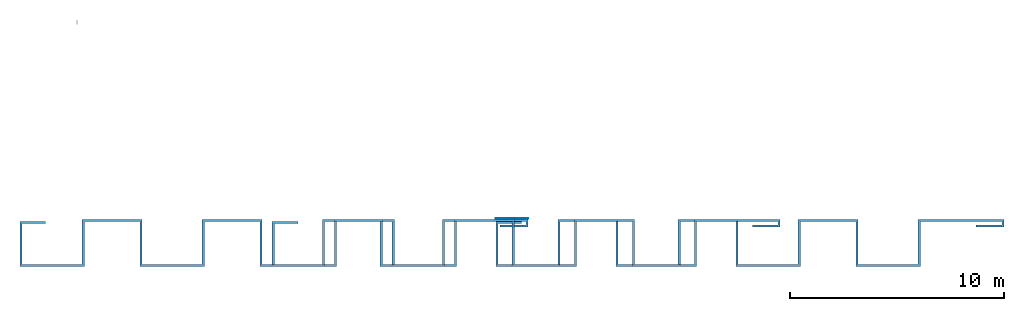
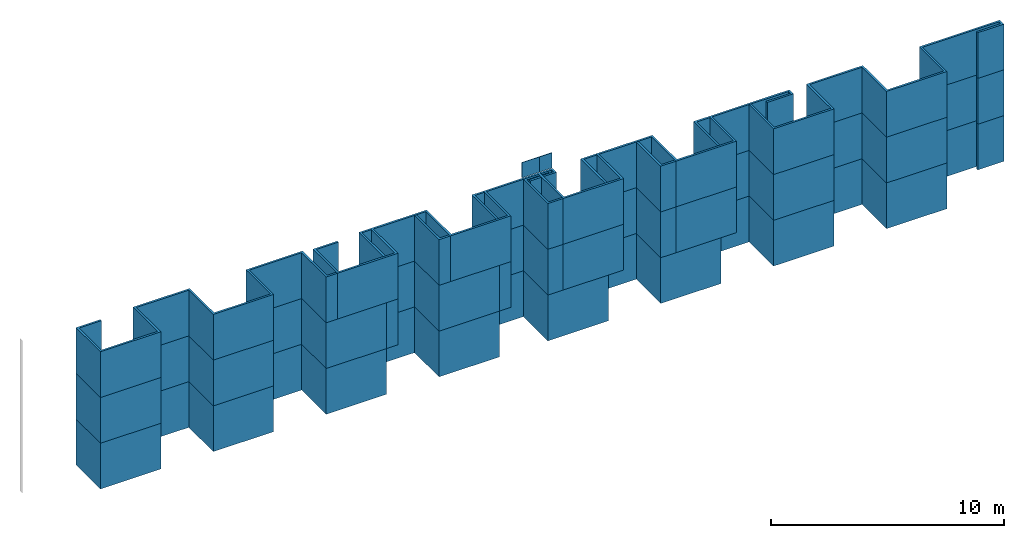
# One storey, part 1 of 2: 8 members, 2 plates, 1 element without a shape of its own.
"""IFC2X3 building model written with IfcOpenShell, lengths in millimetres."""

from ifc_helpers import new_model, entity, si_unit, converted_unit, derived_unit, direction, frame, origin, origin_2d_with_axis, place, context, subcontext, project, spatial, polyline, rectangle, outline, extrude, source, transform, mapped, material, type_object, type_shapes, element, aggregate, save


model = new_model("IFC2X3")

# Units and contexts
model_context = context("Model", 3, precision=0.01, world=origin(), true_north=direction((0.0, 1.0)))
body_context = subcontext(model_context, "Body", "Model", "MODEL_VIEW")
ifc_project = project(units=[si_unit("LENGTHUNIT", "METRE", prefix="MILLI"), si_unit("AREAUNIT", "SQUARE_METRE"), si_unit("VOLUMEUNIT", "CUBIC_METRE"), converted_unit("PLANEANGLEUNIT", "DEGREE", entity("IfcPlaneAngleMeasure", 0.017453292519943278), si_unit("PLANEANGLEUNIT", "RADIAN"), dimensions=[0, 0, 0, 0, 0, 0, 0]), derived_unit("THERMALTRANSMITTANCEUNIT", [(si_unit("MASSUNIT", "GRAM", prefix="KILO"), 1), (si_unit("THERMODYNAMICTEMPERATUREUNIT", "KELVIN"), -1), (si_unit("TIMEUNIT", "SECOND"), -3)])], contexts=[model_context])

# Site, building, storey
site_placement = place(None, origin())
site = spatial("IfcSite", under=ifc_project, at=site_placement, CompositionType="ELEMENT")
building_placement = place(site_placement, origin())
building = spatial("IfcBuilding", under=site, at=building_placement, CompositionType="ELEMENT")
storey_placement = place(building_placement, origin())
storey = spatial("IfcBuildingStorey", under=building, at=storey_placement, CompositionType="ELEMENT", Elevation=0.0)

# Curtain wall, members, plates
curtain_wall_type = type_object("IfcCurtainWallType", Name="Parede cortina", PredefinedType="NOTDEFINED")
curtain_wall_placement = place(storey_placement, origin())
curtain_wall = element("IfcCurtainWall", 1, at=curtain_wall_placement, inside=storey, type_object=curtain_wall_type, Name="Parede cortina")
ifc_material_1 = material()
member_type_1 = type_object("IfcMemberType", Name="Montante retangular:Montante_BIM", PredefinedType="MULLION", material=ifc_material_1)
shared_shape_1 = source(origin(), body_context, "Body", "SweptSolid", [
    extrude(outline(polyline([(-1186.0465116270786, -9204.65116279148), (913.9534883729204, -9204.65116279148), (913.9534883729191, -6404.651162791479), (-1186.04651162708, -6404.651162791479), (-1186.0465116270943, -3604.6511627914792), (913.9534883729046, -3604.651162791466), (913.9534883729248, -804.6511627914637), (-1186.0465116270743, -804.6511627914484), (-1186.0465116271405, 1995.3488372085517), (913.9534883728585, 1995.3488372086038), (913.9534883730562, 4795.348837208604), (-1186.046511626943, 4795.348837208751), (-1186.046511627386, 7595.348837208751), (913.9534883726129, 7595.348837209085), (913.9534883737265, 11595.348837209187), (563.9534883733556, 11595.348837209187), (563.953488373354, 10295.348837209192), (663.9534883733529, 10295.348837209158), (663.9534883737316, 11495.348837209158), (813.9534883737322, 11495.34883720911), (813.9534883725879, 7695.348837209108), (-1286.0465116274113, 7695.34883720974), (-1286.0465116283146, 4695.348837209742), (813.9534883716843, 4695.34883720911), (813.9534883709015, 2095.348837209109), (-1286.0465116290975, 2095.3488372097418), (-1286.0465116291, -904.6511627902587), (813.953488370899, -904.6511627902587), (813.9534883691587, -3504.6511627902587), (-1286.0465116308403, -3504.651162790261), (-1286.046511628313, -6504.651162790258), (813.9534883716858, -6504.651162788489), (813.9534883649992, -9104.651162788494), (-1286.0465116350001, -9104.651162783088), (-1286.0465116012992, -12104.651162791475), (813.9534883455916, -12104.651162791475), (813.9534883729251, -10904.651162791475), (713.9534883729261, -10904.651162791475), (713.9534883729284, -12004.651162791477), (-1186.0465116270727, -12004.65116279148), (-1186.0465116270786, -9204.65116279148)])), frame((-11595.348837209185, 913.9534883729232, -2400.0), z_axis=(0.0, 0.0, 1.0), x_axis=(0.0, -1.0, 0.0)), (0.0, 0.0, 1.0), 2400.0),
])
type_shapes(member_type_1, [shared_shape_1])
member_1_placement = place(curtain_wall_placement, frame((841.8923235076486, -377.18105207786704, 0.0), z_axis=(0.0, 0.0, -1.0), x_axis=(1.0, 0.0, 0.0)))
member_1 = element("IfcMember", 2, at=member_1_placement, type_object=member_type_1, material=ifc_material_1, Name="Montante retangular:Montante_BIM", context=body_context, shape_type="MappedRepresentation", body=[
    mapped(shared_shape_1, transform((0.0, 0.0, 0.0), scale=1.0)),
])
member_type_2 = type_object("IfcMemberType", Name="Montante retangular:Montante_BIM", PredefinedType="MULLION", material=ifc_material_1)
shared_shape_2 = source(origin(), body_context, "Body", "SweptSolid", [
    extrude(outline(polyline([(-1186.0465116270786, -9204.65116279148), (913.9534883729204, -9204.65116279148), (913.9534883729191, -6404.651162791479), (-1186.04651162708, -6404.651162791479), (-1186.0465116270943, -3604.6511627914792), (913.9534883729046, -3604.651162791466), (913.9534883729248, -804.6511627914637), (-1186.0465116270743, -804.6511627914484), (-1186.0465116271405, 1995.3488372085517), (913.9534883728585, 1995.3488372086038), (913.9534883730562, 4795.348837208604), (-1186.046511626943, 4795.348837208751), (-1186.046511627386, 7595.348837208751), (913.9534883726129, 7595.348837209085), (913.9534883737265, 11595.348837209187), (563.9534883733556, 11595.348837209187), (563.953488373354, 10295.348837209192), (663.9534883733529, 10295.348837209158), (663.9534883737316, 11495.348837209158), (813.9534883737322, 11495.34883720911), (813.9534883725879, 7695.348837209108), (-1286.0465116274113, 7695.34883720974), (-1286.0465116283146, 4695.348837209742), (813.9534883716843, 4695.34883720911), (813.9534883709015, 2095.348837209109), (-1286.0465116290975, 2095.3488372097418), (-1286.0465116291, -904.6511627902587), (813.953488370899, -904.6511627902587), (813.9534883691587, -3504.6511627902587), (-1286.0465116308403, -3504.651162790261), (-1286.046511628313, -6504.651162790258), (813.9534883716858, -6504.651162788489), (813.9534883649992, -9104.651162788494), (-1286.0465116350001, -9104.651162783088), (-1286.0465116012992, -12104.651162791475), (813.9534883455916, -12104.651162791475), (813.9534883729251, -10904.651162791475), (713.9534883729261, -10904.651162791475), (713.9534883729284, -12004.651162791477), (-1186.0465116270727, -12004.65116279148), (-1186.0465116270786, -9204.65116279148)])), frame((-11595.348837209185, 913.9534883729232, -2400.0), z_axis=(0.0, 0.0, 1.0), x_axis=(0.0, -1.0, 0.0)), (0.0, 0.0, 1.0), 2400.0),
])
type_shapes(member_type_2, [shared_shape_2])
member_2_placement = place(curtain_wall_placement, frame((841.8923235076486, -377.18105207786704, 2400.0), z_axis=(0.0, 0.0, -1.0), x_axis=(1.0, 0.0, 0.0)))
member_2 = element("IfcMember", 3, at=member_2_placement, type_object=member_type_2, material=ifc_material_1, Name="Montante retangular:Montante_BIM", context=body_context, shape_type="MappedRepresentation", body=[
    mapped(shared_shape_2, transform((0.0, 0.0, 0.0), scale=1.0)),
])
member_type_3 = type_object("IfcMemberType", Name="Montante retangular:Montante_BIM", PredefinedType="MULLION", material=ifc_material_1)
shared_shape_3 = source(origin(), body_context, "Body", "SweptSolid", [
    extrude(outline(polyline([(-1186.0465116270786, -9204.65116279148), (913.9534883729204, -9204.65116279148), (913.9534883729191, -6404.651162791479), (-1186.04651162708, -6404.651162791479), (-1186.0465116270943, -3604.6511627914792), (913.9534883729046, -3604.651162791466), (913.9534883729248, -804.6511627914637), (-1186.0465116270743, -804.6511627914484), (-1186.0465116271405, 1995.3488372085517), (913.9534883728585, 1995.3488372086038), (913.9534883730562, 4795.348837208604), (-1186.046511626943, 4795.348837208751), (-1186.046511627386, 7595.348837208751), (913.9534883726129, 7595.348837209085), (913.9534883737265, 11595.348837209187), (563.9534883733556, 11595.348837209187), (563.953488373354, 10295.348837209192), (663.9534883733529, 10295.348837209158), (663.9534883737316, 11495.348837209158), (813.9534883737322, 11495.34883720911), (813.9534883725879, 7695.348837209108), (-1286.0465116274113, 7695.34883720974), (-1286.0465116283146, 4695.348837209742), (813.9534883716843, 4695.34883720911), (813.9534883709015, 2095.348837209109), (-1286.0465116290975, 2095.3488372097418), (-1286.0465116291, -904.6511627902587), (813.953488370899, -904.6511627902587), (813.9534883691587, -3504.6511627902587), (-1286.0465116308403, -3504.651162790261), (-1286.046511628313, -6504.651162790258), (813.9534883716858, -6504.651162788489), (813.9534883649992, -9104.651162788494), (-1286.0465116350001, -9104.651162783088), (-1286.0465116012992, -12104.651162791475), (813.9534883455916, -12104.651162791475), (813.9534883729251, -10904.651162791475), (713.9534883729261, -10904.651162791475), (713.9534883729284, -12004.651162791477), (-1186.0465116270727, -12004.65116279148), (-1186.0465116270786, -9204.65116279148)])), frame((-11595.348837209185, 913.9534883729232, -2400.0), z_axis=(0.0, 0.0, 1.0), x_axis=(0.0, -1.0, 0.0)), (0.0, 0.0, 1.0), 2400.0),
])
type_shapes(member_type_3, [shared_shape_3])
member_3_placement = place(curtain_wall_placement, frame((841.8923235076481, -377.18105207786704, 4800.0), z_axis=(0.0, 0.0, -1.0), x_axis=(1.0, 0.0, 0.0)))
member_3 = element("IfcMember", 4, at=member_3_placement, type_object=member_type_3, material=ifc_material_1, Name="Montante retangular:Montante_BIM", context=body_context, shape_type="MappedRepresentation", body=[
    mapped(shared_shape_3, transform((0.0, 0.0, 0.0), scale=1.0)),
])
member_type_4 = type_object("IfcMemberType", Name="Montante retangular:Montante_BIM", PredefinedType="MULLION", material=ifc_material_1)
shared_shape_4 = source(origin(), body_context, "Body", "SweptSolid", [
    extrude(outline(polyline([(9204.651162791473, -1186.0465116270975), (9204.651162791477, 913.9534883729016), (6404.651162791477, 913.9534883729059), (6404.651162791472, -1186.0465116270932), (3604.651162791472, -1186.0465116271018), (3604.6511627914633, 913.9534883728971), (804.6511627914633, 913.9534883729232), (804.6511627914417, -1186.046511627076), (-1995.3488372085585, -1186.0465116271366), (-1995.3488372086063, 913.9534883728626), (-4795.348837208607, 913.9534883730661), (-4795.348837208758, -1186.046511626933), (-7595.348837208756, -1186.0465116273704), (-7595.348837209085, 913.9534883726286), (-11595.348837209189, 913.9534883737505), (-11595.348837209189, 563.9534883733796), (-10295.348837209194, 563.9534883733752), (-10295.34883720916, 663.9534883733742), (-11495.34883720916, 663.9534883737554), (-11495.348837209112, 813.9534883737559), (-7695.34883720911, 813.9534883726037), (-7695.348837209747, -1286.0465116273954), (-4695.348837209749, -1286.0465116283049), (-4695.348837209112, 813.9534883716941), (-2095.348837209112, 813.9534883709058), (-2095.3488372097486, -1286.0465116290932), (904.6511627902516, -1286.046511629102), (904.651162790256, 813.9534883708972), (3504.651162790256, 813.9534883691515), (3504.651162790253, -1286.0465116308476), (6504.651162790253, -1286.0465116283267), (6504.651162788488, 813.9534883716725), (9104.651162788488, 813.9534883649803), (9104.651162783084, -1286.0465116350188), (12104.65116279147, -1286.0465116013243), (12104.651162791473, 813.9534883455667), (10904.651162791473, 813.9534883729026), (10904.651162791473, 713.9534883729036), (12004.651162791475, 713.9534883729036), (12004.651162791475, -1186.0465116270975), (9204.651162791473, -1186.0465116270975)])), frame((-12104.65116279147, 913.9534883729232, -2400.0), z_axis=(0.0, 0.0, -1.0), x_axis=(1.0, 0.0, 0.0)), (0.0, 0.0, -1.0), 2400.0000000000005),
])
type_shapes(member_type_4, [shared_shape_4])
member_4_placement = place(curtain_wall_placement, frame((-658.107676492351, -377.18105207786215, 2400.0), z_axis=(0.0, 0.0, 1.0), x_axis=(-1.0, 0.0, 0.0)))
member_4 = element("IfcMember", 5, at=member_4_placement, type_object=member_type_4, material=ifc_material_1, Name="Montante retangular:Montante_BIM", context=body_context, shape_type="MappedRepresentation", body=[
    mapped(shared_shape_4, transform((0.0, 0.0, 0.0), scale=1.0)),
])
member_type_5 = type_object("IfcMemberType", Name="Montante retangular:Montante_BIM", PredefinedType="MULLION", material=ifc_material_1)
shared_shape_5 = source(origin(), body_context, "Body", "SweptSolid", [
    extrude(outline(polyline([(9204.651162791473, -1186.0465116270975), (9204.651162791477, 913.9534883729016), (6404.651162791477, 913.9534883729059), (6404.651162791472, -1186.0465116270932), (3604.651162791472, -1186.0465116271018), (3604.6511627914633, 913.9534883728971), (804.6511627914633, 913.9534883729232), (804.6511627914417, -1186.046511627076), (-1995.3488372085585, -1186.0465116271366), (-1995.3488372086063, 913.9534883728626), (-4795.348837208607, 913.9534883730661), (-4795.348837208758, -1186.046511626933), (-7595.348837208756, -1186.0465116273704), (-7595.348837209085, 913.9534883726286), (-11595.348837209189, 913.9534883737505), (-11595.348837209189, 563.9534883733796), (-10295.348837209194, 563.9534883733752), (-10295.34883720916, 663.9534883733742), (-11495.34883720916, 663.9534883737554), (-11495.348837209112, 813.9534883737559), (-7695.34883720911, 813.9534883726037), (-7695.348837209747, -1286.0465116273954), (-4695.348837209749, -1286.0465116283049), (-4695.348837209112, 813.9534883716941), (-2095.348837209112, 813.9534883709058), (-2095.3488372097486, -1286.0465116290932), (904.6511627902516, -1286.046511629102), (904.651162790256, 813.9534883708972), (3504.651162790256, 813.9534883691515), (3504.651162790253, -1286.0465116308476), (6504.651162790253, -1286.0465116283267), (6504.651162788488, 813.9534883716725), (9104.651162788488, 813.9534883649803), (9104.651162783084, -1286.0465116350188), (12104.65116279147, -1286.0465116013243), (12104.651162791473, 813.9534883455667), (10904.651162791473, 813.9534883729026), (10904.651162791473, 713.9534883729036), (12004.651162791475, 713.9534883729036), (12004.651162791475, -1186.0465116270975), (9204.651162791473, -1186.0465116270975)])), frame((-12104.65116279147, 913.9534883729232, -2400.0), z_axis=(0.0, 0.0, -1.0), x_axis=(1.0, 0.0, 0.0)), (0.0, 0.0, -1.0), 2400.0),
])
type_shapes(member_type_5, [shared_shape_5])
member_5_placement = place(curtain_wall_placement, frame((-658.107676492351, -377.18105207786215, 4800.0), z_axis=(0.0, 0.0, 1.0), x_axis=(-1.0, 0.0, 0.0)))
member_5 = element("IfcMember", 6, at=member_5_placement, type_object=member_type_5, material=ifc_material_1, Name="Montante retangular:Montante_BIM", context=body_context, shape_type="MappedRepresentation", body=[
    mapped(shared_shape_5, transform((0.0, 0.0, 0.0), scale=1.0)),
])
member_type_6 = type_object("IfcMemberType", Name="Montante retangular:Montante_BIM", PredefinedType="MULLION", material=ifc_material_1)
shared_shape_6 = source(origin(), body_context, "Body", "SweptSolid", [
    extrude(outline(polyline([(9204.651162791473, -1186.0465116270975), (9204.651162791477, 913.9534883729016), (6404.651162791477, 913.9534883729059), (6404.651162791472, -1186.0465116270932), (3604.651162791472, -1186.0465116271018), (3604.6511627914633, 913.9534883728971), (804.6511627914633, 913.9534883729232), (804.6511627914417, -1186.046511627076), (-1995.3488372085585, -1186.0465116271366), (-1995.3488372086063, 913.9534883728626), (-4795.348837208607, 913.9534883730661), (-4795.348837208758, -1186.046511626933), (-7595.348837208756, -1186.0465116273704), (-7595.348837209085, 913.9534883726286), (-11595.348837209189, 913.9534883737505), (-11595.348837209189, 563.9534883733796), (-10295.348837209194, 563.9534883733752), (-10295.34883720916, 663.9534883733742), (-11495.34883720916, 663.9534883737554), (-11495.348837209112, 813.9534883737559), (-7695.34883720911, 813.9534883726037), (-7695.348837209747, -1286.0465116273954), (-4695.348837209749, -1286.0465116283049), (-4695.348837209112, 813.9534883716941), (-2095.348837209112, 813.9534883709058), (-2095.3488372097486, -1286.0465116290932), (904.6511627902516, -1286.046511629102), (904.651162790256, 813.9534883708972), (3504.651162790256, 813.9534883691515), (3504.651162790253, -1286.0465116308476), (6504.651162790253, -1286.0465116283267), (6504.651162788488, 813.9534883716725), (9104.651162788488, 813.9534883649803), (9104.651162783084, -1286.0465116350188), (12104.65116279147, -1286.0465116013243), (12104.651162791473, 813.9534883455667), (10904.651162791473, 813.9534883729026), (10904.651162791473, 713.9534883729036), (12004.651162791475, 713.9534883729036), (12004.651162791475, -1186.0465116270975), (9204.651162791473, -1186.0465116270975)])), frame((-12104.65116279147, 913.9534883729232, -2400.0), z_axis=(0.0, 0.0, -1.0), x_axis=(1.0, 0.0, 0.0)), (0.0, 0.0, -1.0), 2400.0),
])
type_shapes(member_type_6, [shared_shape_6])
member_6_placement = place(curtain_wall_placement, frame((-658.107676492351, -377.18105207786215, 7200.0), z_axis=(0.0, 0.0, 1.0), x_axis=(-1.0, 0.0, 0.0)))
member_6 = element("IfcMember", 7, at=member_6_placement, type_object=member_type_6, material=ifc_material_1, Name="Montante retangular:Montante_BIM", context=body_context, shape_type="MappedRepresentation", body=[
    mapped(shared_shape_6, transform((0.0, 0.0, 0.0), scale=1.0)),
])
member_type_7 = type_object("IfcMemberType", Name="Montante retangular:Montante_BIM", PredefinedType="MULLION", material=ifc_material_1)
shared_shape_7 = source(origin(), body_context, "Body", "SweptSolid", [
    extrude(outline(polyline([(-1186.046511627083, -9204.651162791475), (913.9534883729161, -9204.651162791475), (913.9534883729161, -6404.651162791474), (-1186.046511627083, -6404.651162791473), (-1186.046511627098, -3604.651162791473), (913.9534883729032, -3604.6511627914615), (913.9534883729269, -804.6511627914613), (-1186.0465116270743, -804.6511627914429), (-1186.0465116271414, 1995.3488372085571), (913.9534883728577, 1995.348837208608), (913.953488373059, 4795.3488372086085), (-1186.0465116269422, 4795.348837208757), (-1186.0465116273817, 7595.348837208757), (913.9534883726172, 7595.34883720909), (913.9534883737329, 11595.348837209192), (563.953488373362, 11595.348837209189), (563.9534883733597, 10295.348837209194), (663.9534883733586, 10295.34883720916), (663.953488373738, 11495.34883720916), (813.9534883737385, 11495.348837209114), (813.9534883725922, 7695.348837209112), (-1286.0465116274067, 7695.348837209745), (-1286.046511628314, 4695.348837209747), (813.9534883716872, 4695.348837209113), (813.953488370903, 2095.3488372091138), (-1286.0465116290982, 2095.348837209747), (-1286.0465116291023, -904.651162790253), (813.9534883708989, -904.651162790254), (813.9534883691574, -3504.6511627902546), (-1286.0465116308437, -3504.6511627902546), (-1286.0465116283183, -6504.651162790255), (813.9534883716829, -6504.651162788486), (813.9534883649948, -9104.651162788487), (-1286.0465116350063, -9104.651162783086), (-1286.0465116013072, -12104.651162791472), (813.953488345588, -12104.651162791472), (813.9534883729199, -10904.651162791472), (713.9534883729189, -10904.651162791472), (713.9534883729204, -12004.651162791473), (-1186.0465116270786, -12004.651162791477), (-1186.046511627083, -9204.651162791475)])), frame((804.6511627914648, 913.9534883729236, -2400.0), z_axis=(0.0, 0.0, 1.0), x_axis=(0.0, -1.0, 0.0)), (0.0, 0.0, 1.0), 2400.0),
])
type_shapes(member_type_7, [shared_shape_7])
member_7_placement = place(curtain_wall_placement, frame((201.89232381244528, -377.18105207786493, 2400.0), z_axis=(0.0, 0.0, -1.0), x_axis=(1.0, 0.0, 0.0)))
member_7 = element("IfcMember", 8, at=member_7_placement, type_object=member_type_7, material=ifc_material_1, Name="Montante retangular:Montante_BIM", context=body_context, shape_type="MappedRepresentation", body=[
    mapped(shared_shape_7, transform((0.0, 0.0, 0.0), scale=1.0)),
])
member_type_8 = type_object("IfcMemberType", Name="Montante retangular:Montante_BIM", PredefinedType="MULLION", material=ifc_material_1)
shared_shape_8 = source(origin(), body_context, "Body", "SweptSolid", [
    extrude(outline(polyline([(-1186.046511627083, -9204.651162791475), (913.9534883729161, -9204.651162791475), (913.9534883729161, -6404.651162791474), (-1186.046511627083, -6404.651162791473), (-1186.046511627098, -3604.651162791473), (913.9534883729032, -3604.6511627914615), (913.9534883729269, -804.6511627914613), (-1186.0465116270743, -804.6511627914429), (-1186.0465116271414, 1995.3488372085571), (913.9534883728577, 1995.348837208608), (913.953488373059, 4795.3488372086085), (-1186.0465116269422, 4795.348837208757), (-1186.0465116273817, 7595.348837208757), (913.9534883726172, 7595.34883720909), (913.9534883737329, 11595.348837209192), (563.953488373362, 11595.348837209189), (563.9534883733597, 10295.348837209194), (663.9534883733586, 10295.34883720916), (663.953488373738, 11495.34883720916), (813.9534883737385, 11495.348837209114), (813.9534883725922, 7695.348837209112), (-1286.0465116274067, 7695.348837209745), (-1286.046511628314, 4695.348837209747), (813.9534883716872, 4695.348837209113), (813.953488370903, 2095.3488372091138), (-1286.0465116290982, 2095.348837209747), (-1286.0465116291023, -904.651162790253), (813.9534883708989, -904.651162790254), (813.9534883691574, -3504.6511627902546), (-1286.0465116308437, -3504.6511627902546), (-1286.0465116283183, -6504.651162790255), (813.9534883716829, -6504.651162788486), (813.9534883649948, -9104.651162788487), (-1286.0465116350063, -9104.651162783086), (-1286.0465116013072, -12104.651162791472), (813.953488345588, -12104.651162791472), (813.9534883729199, -10904.651162791472), (713.9534883729189, -10904.651162791472), (713.9534883729204, -12004.651162791473), (-1186.0465116270786, -12004.651162791477), (-1186.046511627083, -9204.651162791475)])), frame((804.6511627914648, 913.9534883729236, -2400.0), z_axis=(0.0, 0.0, 1.0), x_axis=(0.0, -1.0, 0.0)), (0.0, 0.0, 1.0), 2400.0),
])
type_shapes(member_type_8, [shared_shape_8])
member_8_placement = place(curtain_wall_placement, frame((201.892323812445, -377.18105207786493, 4800.0), z_axis=(0.0, 0.0, -1.0), x_axis=(1.0, 0.0, 0.0)))
member_8 = element("IfcMember", 9, at=member_8_placement, type_object=member_type_8, material=ifc_material_1, Name="Montante retangular:Montante_BIM", context=body_context, shape_type="MappedRepresentation", body=[
    mapped(shared_shape_8, transform((0.0, 0.0, 0.0), scale=1.0)),
])
ifc_material_2 = material(Name="Vidro")
plate_type_1 = type_object("IfcPlateType", PredefinedType="CURTAIN_PANEL", material=ifc_material_2)
shared_shape_9 = source(origin(), body_context, "Body", "SweptSolid", [
    extrude(rectangle(XDim=25.0, YDim=860.0000003047962, at=origin_2d_with_axis()), frame((0.0, 37.0, 0.0), z_axis=(0.0, 0.0, 1.0), x_axis=(0.0, 1.0, 0.0)), (0.0, 0.0, 1.0), 800.0),
])
type_shapes(plate_type_1, [shared_shape_9])
plate_1_placement = place(curtain_wall_placement, frame((-228.1076763399528, -377.1810520778635, 7200.0)))
plate_1 = element("IfcPlate", 10, at=plate_1_placement, type_object=plate_type_1, material=ifc_material_2, context=body_context, shape_type="MappedRepresentation", body=[
    mapped(shared_shape_9, transform((0.0, 0.0, 0.0), scale=1.0)),
])
plate_type_2 = type_object("IfcPlateType", PredefinedType="CURTAIN_PANEL", material=ifc_material_2)
shared_shape_10 = source(origin(), body_context, "Body", "SweptSolid", [
    extrude(rectangle(XDim=25.0, YDim=639.9999996952056, at=origin_2d_with_axis()), frame((0.0, 37.0, 0.0), z_axis=(0.0, 0.0, 1.0), x_axis=(0.0, 1.0, 0.0)), (0.0, 0.0, 1.0), 800.0),
])
type_shapes(plate_type_2, [shared_shape_10])
plate_2_placement = place(curtain_wall_placement, frame((521.8923236600467, -377.18105207786596, 7200.0)))
plate_2 = element("IfcPlate", 11, at=plate_2_placement, type_object=plate_type_2, material=ifc_material_2, context=body_context, shape_type="MappedRepresentation", body=[
    mapped(shared_shape_10, transform((0.0, 0.0, 0.0), scale=1.0)),
])
aggregate(curtain_wall, [plate_1, plate_2, member_1, member_2, member_3, member_4, member_5, member_6, member_7, member_8])

save(model, "model.ifc")
